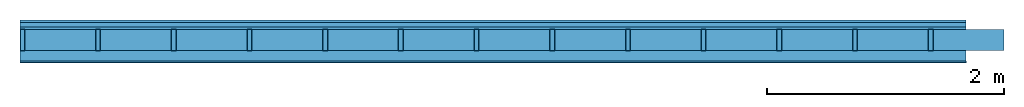
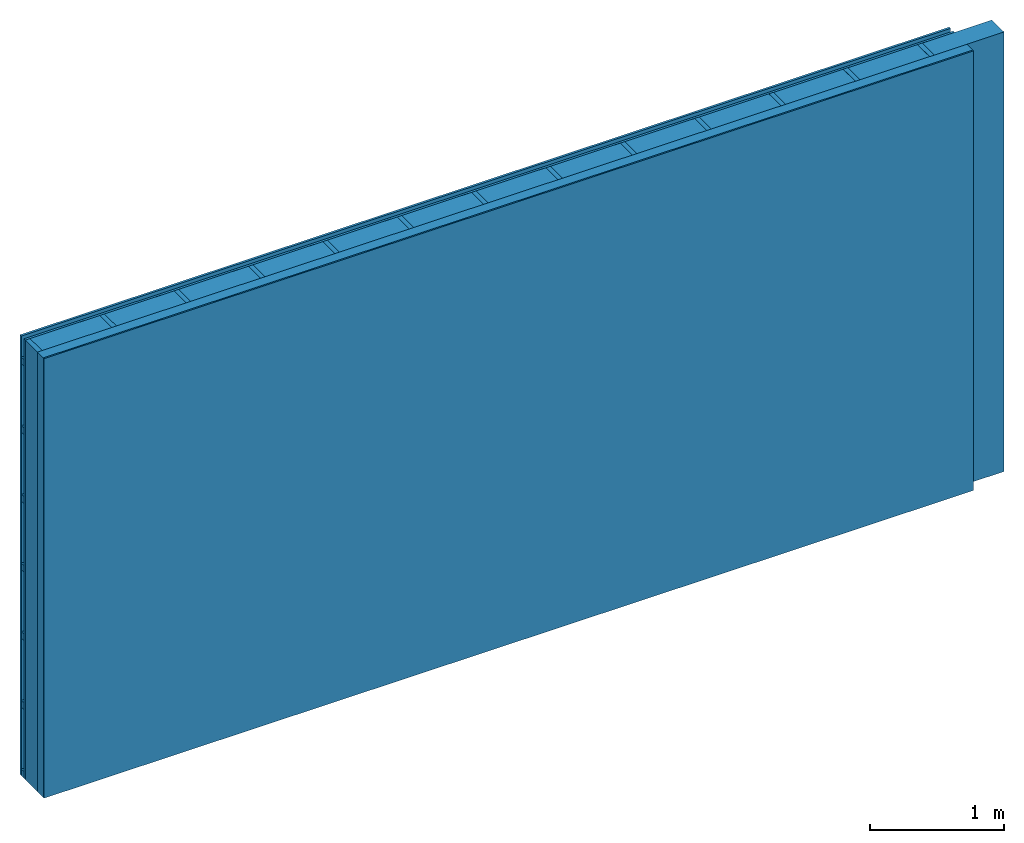
# One storey: 4 plates, 3 members, 1 element without a shape of its own.
"""IFC4 building model written with IfcOpenShell, lengths in metres."""

from ifc_helpers import new_model, si_unit, derived_unit, direction, frame, frame_2d, origin, origin_with_axes, place, context, project, spatial, rectangle, extrude, material, layer, layer_set, type_object, element, aggregate, save


model = new_model("IFC4")

# Units and contexts
plan_context = context("Plan", 3, precision=1e-05, world=origin(), true_north=direction((0.0, 1.0)))
model_context = context("Model", 3, precision=1e-05, world=origin(), true_north=direction((0.0, 1.0)))
ifc_project = project(units=[si_unit("LENGTHUNIT", "METRE"), derived_unit("SOUNDPRESSUREUNIT", [(si_unit("PRESSUREUNIT", "PASCAL", prefix="MICRO"), 0)]), si_unit("ENERGYUNIT", "JOULE", prefix="MEGA"), si_unit("MASSUNIT", "GRAM", prefix="KILO"), derived_unit("THERMALTRANSMITTANCEUNIT", [(si_unit("POWERUNIT", "WATT"), 1), (si_unit("AREAUNIT", "SQUARE_METRE"), -1), (si_unit("THERMODYNAMICTEMPERATUREUNIT", "KELVIN"), -1)]), derived_unit("AREADENSITYUNIT", [(si_unit("MASSUNIT", "GRAM", prefix="KILO"), 1), (si_unit("AREAUNIT", "SQUARE_METRE"), -1)]), derived_unit("USERDEFINED", [(si_unit("ENERGYUNIT", "JOULE", prefix="MEGA"), 1), (si_unit("AREAUNIT", "SQUARE_METRE"), -1)])], contexts=[plan_context, model_context])

# Site, building, storey
site = spatial("IfcSite", under=ifc_project)
building_placement = place(None, origin())
building = spatial("IfcBuilding", under=site, at=building_placement)
storey_placement = place(building_placement, origin())
storey = spatial("IfcBuildingStorey", under=building, at=storey_placement)

# Wall, members, plates
ifc_material_1 = material(Name="Wood cladding horizontal, closed")
ifc_layer_1 = layer(ifc_material_1, 0.02, Name="Cover 1st layer")
ifc_layer_2 = layer(None, 0.04, Name="Battens / profiles (ventilation)")
ifc_material_2 = material(Category="10.009")
ifc_layer_3 = layer(ifc_material_2, 0.02, Name="outside 1st layer")
ifc_material_3 = material(Name="of the art")
ifc_layer_4 = layer(ifc_material_3, 0.0, Name="Bond")
ifc_layer_5 = layer(None, 0.18, Name="Support")
ifc_layer_6 = layer(ifc_material_3, 0.0, Name="Bond")
ifc_material_4 = material(Name="Solid timber panel")
ifc_layer_7 = layer(ifc_material_4, 0.087, Name="1st layer")
ifc_material_5 = material(Name="Plasterboard type A", Category="03.008")
ifc_layer_8 = layer(ifc_material_5, 0.0125, Name="Covering 1st layer")
ifc_material_6 = material(Name="joints", Category="04.017")
ifc_layer_9 = layer(ifc_material_6, 0.0, Name="Surface")
ifc_layer_set = layer_set([ifc_layer_1, ifc_layer_2, ifc_layer_3, ifc_layer_4, ifc_layer_5, ifc_layer_6, ifc_layer_7, ifc_layer_8, ifc_layer_9])
wall_type = type_object("IfcWallType", Name="D1015", PredefinedType="NOTDEFINED", material=ifc_layer_set)
wall_placement = place(None, frame((0.0, 0.0, 0.0), z_axis=(0.0, -1.0, 0.0), x_axis=(1.0, 0.0, 0.0)))
wall = element("IfcWall", 1, at=wall_placement, inside=storey, type_object=wall_type, material=ifc_layer_set, Name="Wall #1")
ifc_material_7 = material()
member_1_placement = place(wall_placement, origin())
member_1 = element("IfcMember", 2, at=member_1_placement, material=ifc_material_7, Name="Battens / profiles (ventilation)", context=plan_context, shape_type="SweptSolid", body=[
    extrude(rectangle(XDim=0.06, YDim=0.04, at=frame_2d((0.03, 0.02), x_axis=(1.0, 0.0))), frame((0.0, 0.0, 0.02), z_axis=(1.0, 0.0, 0.0), x_axis=(0.0, 1.0, 0.0)), (0.0, 0.0, 1.0), 8.0),
    extrude(rectangle(XDim=0.06, YDim=0.04, at=frame_2d((0.03, 0.02), x_axis=(1.0, 0.0))), frame((0.0, 0.625, 0.02), z_axis=(1.0, 0.0, 0.0), x_axis=(0.0, 1.0, 0.0)), (0.0, 0.0, 1.0), 8.0),
    extrude(rectangle(XDim=0.06, YDim=0.04, at=frame_2d((0.03, 0.02), x_axis=(1.0, 0.0))), frame((0.0, 1.25, 0.02), z_axis=(1.0, 0.0, 0.0), x_axis=(0.0, 1.0, 0.0)), (0.0, 0.0, 1.0), 8.0),
    extrude(rectangle(XDim=0.06, YDim=0.04, at=frame_2d((0.03, 0.02), x_axis=(1.0, 0.0))), frame((0.0, 1.875, 0.02), z_axis=(1.0, 0.0, 0.0), x_axis=(0.0, 1.0, 0.0)), (0.0, 0.0, 1.0), 8.0),
    extrude(rectangle(XDim=0.06, YDim=0.04, at=frame_2d((0.03, 0.02), x_axis=(1.0, 0.0))), frame((0.0, 2.5, 0.02), z_axis=(1.0, 0.0, 0.0), x_axis=(0.0, 1.0, 0.0)), (0.0, 0.0, 1.0), 8.0),
    extrude(rectangle(XDim=0.06, YDim=0.04, at=frame_2d((0.03, 0.02), x_axis=(1.0, 0.0))), frame((0.0, 3.125, 0.02), z_axis=(1.0, 0.0, 0.0), x_axis=(0.0, 1.0, 0.0)), (0.0, 0.0, 1.0), 8.0),
    extrude(rectangle(XDim=0.06, YDim=0.04, at=frame_2d((0.03, 0.02), x_axis=(1.0, 0.0))), frame((0.0, 3.75, 0.02), z_axis=(1.0, 0.0, 0.0), x_axis=(0.0, 1.0, 0.0)), (0.0, 0.0, 1.0), 8.0),
])
ifc_material_8 = material()
member_2_placement = place(wall_placement, origin())
member_2 = element("IfcMember", 3, at=member_2_placement, material=ifc_material_8, Name="Support", context=plan_context, shape_type="SweptSolid", body=[
    extrude(rectangle(XDim=0.04, YDim=0.18, at=frame_2d((0.02, 0.09), x_axis=(1.0, 0.0))), frame((0.0, 4.0, 0.08), z_axis=(0.0, -1.0, 0.0), x_axis=(1.0, 0.0, 0.0)), (0.0, 0.0, 1.0), 4.0),
    extrude(rectangle(XDim=0.04, YDim=0.18, at=frame_2d((0.02, 0.09), x_axis=(1.0, 0.0))), frame((0.64, 4.0, 0.08), z_axis=(0.0, -1.0, 0.0), x_axis=(1.0, 0.0, 0.0)), (0.0, 0.0, 1.0), 4.0),
    extrude(rectangle(XDim=0.04, YDim=0.18, at=frame_2d((0.02, 0.09), x_axis=(1.0, 0.0))), frame((1.28, 4.0, 0.08), z_axis=(0.0, -1.0, 0.0), x_axis=(1.0, 0.0, 0.0)), (0.0, 0.0, 1.0), 4.0),
    extrude(rectangle(XDim=0.04, YDim=0.18, at=frame_2d((0.02, 0.09), x_axis=(1.0, 0.0))), frame((1.92, 4.0, 0.08), z_axis=(0.0, -1.0, 0.0), x_axis=(1.0, 0.0, 0.0)), (0.0, 0.0, 1.0), 4.0),
    extrude(rectangle(XDim=0.04, YDim=0.18, at=frame_2d((0.02, 0.09), x_axis=(1.0, 0.0))), frame((2.56, 4.0, 0.08), z_axis=(0.0, -1.0, 0.0), x_axis=(1.0, 0.0, 0.0)), (0.0, 0.0, 1.0), 4.0),
    extrude(rectangle(XDim=0.04, YDim=0.18, at=frame_2d((0.02, 0.09), x_axis=(1.0, 0.0))), frame((3.2, 4.0, 0.08), z_axis=(0.0, -1.0, 0.0), x_axis=(1.0, 0.0, 0.0)), (0.0, 0.0, 1.0), 4.0),
    extrude(rectangle(XDim=0.04, YDim=0.18, at=frame_2d((0.02, 0.09), x_axis=(1.0, 0.0))), frame((3.84, 4.0, 0.08), z_axis=(0.0, -1.0, 0.0), x_axis=(1.0, 0.0, 0.0)), (0.0, 0.0, 1.0), 4.0),
    extrude(rectangle(XDim=0.04, YDim=0.18, at=frame_2d((0.02, 0.09), x_axis=(1.0, 0.0))), frame((4.48, 4.0, 0.08), z_axis=(0.0, -1.0, 0.0), x_axis=(1.0, 0.0, 0.0)), (0.0, 0.0, 1.0), 4.0),
    extrude(rectangle(XDim=0.04, YDim=0.18, at=frame_2d((0.02, 0.09), x_axis=(1.0, 0.0))), frame((5.12, 4.0, 0.08), z_axis=(0.0, -1.0, 0.0), x_axis=(1.0, 0.0, 0.0)), (0.0, 0.0, 1.0), 4.0),
    extrude(rectangle(XDim=0.04, YDim=0.18, at=frame_2d((0.02, 0.09), x_axis=(1.0, 0.0))), frame((5.76, 4.0, 0.08), z_axis=(0.0, -1.0, 0.0), x_axis=(1.0, 0.0, 0.0)), (0.0, 0.0, 1.0), 4.0),
    extrude(rectangle(XDim=0.04, YDim=0.18, at=frame_2d((0.02, 0.09), x_axis=(1.0, 0.0))), frame((6.4, 4.0, 0.08), z_axis=(0.0, -1.0, 0.0), x_axis=(1.0, 0.0, 0.0)), (0.0, 0.0, 1.0), 4.0),
    extrude(rectangle(XDim=0.04, YDim=0.18, at=frame_2d((0.02, 0.09), x_axis=(1.0, 0.0))), frame((7.04, 4.0, 0.08), z_axis=(0.0, -1.0, 0.0), x_axis=(1.0, 0.0, 0.0)), (0.0, 0.0, 1.0), 4.0),
    extrude(rectangle(XDim=0.04, YDim=0.18, at=frame_2d((0.02, 0.09), x_axis=(1.0, 0.0))), frame((7.68, 4.0, 0.08), z_axis=(0.0, -1.0, 0.0), x_axis=(1.0, 0.0, 0.0)), (0.0, 0.0, 1.0), 4.0),
])
ifc_material_9 = material(Name="wool")
member_3_placement = place(wall_placement, origin())
member_3 = element("IfcMember", 4, at=member_3_placement, material=ifc_material_9, Name="Cavity", context=plan_context, shape_type="SweptSolid", body=[
    extrude(rectangle(XDim=0.6, YDim=0.18, at=frame_2d((0.3, 0.09), x_axis=(1.0, 0.0))), frame((0.04, 4.0, 0.08), z_axis=(0.0, -1.0, 0.0), x_axis=(1.0, 0.0, 0.0)), (0.0, 0.0, 1.0), 4.0),
    extrude(rectangle(XDim=0.6, YDim=0.18, at=frame_2d((0.3, 0.09), x_axis=(1.0, 0.0))), frame((0.68, 4.0, 0.08), z_axis=(0.0, -1.0, 0.0), x_axis=(1.0, 0.0, 0.0)), (0.0, 0.0, 1.0), 4.0),
    extrude(rectangle(XDim=0.6, YDim=0.18, at=frame_2d((0.3, 0.09), x_axis=(1.0, 0.0))), frame((1.32, 4.0, 0.08), z_axis=(0.0, -1.0, 0.0), x_axis=(1.0, 0.0, 0.0)), (0.0, 0.0, 1.0), 4.0),
    extrude(rectangle(XDim=0.6, YDim=0.18, at=frame_2d((0.3, 0.09), x_axis=(1.0, 0.0))), frame((1.96, 4.0, 0.08), z_axis=(0.0, -1.0, 0.0), x_axis=(1.0, 0.0, 0.0)), (0.0, 0.0, 1.0), 4.0),
    extrude(rectangle(XDim=0.6, YDim=0.18, at=frame_2d((0.3, 0.09), x_axis=(1.0, 0.0))), frame((2.6, 4.0, 0.08), z_axis=(0.0, -1.0, 0.0), x_axis=(1.0, 0.0, 0.0)), (0.0, 0.0, 1.0), 4.0),
    extrude(rectangle(XDim=0.6, YDim=0.18, at=frame_2d((0.3, 0.09), x_axis=(1.0, 0.0))), frame((3.24, 4.0, 0.08), z_axis=(0.0, -1.0, 0.0), x_axis=(1.0, 0.0, 0.0)), (0.0, 0.0, 1.0), 4.0),
    extrude(rectangle(XDim=0.6, YDim=0.18, at=frame_2d((0.3, 0.09), x_axis=(1.0, 0.0))), frame((3.88, 4.0, 0.08), z_axis=(0.0, -1.0, 0.0), x_axis=(1.0, 0.0, 0.0)), (0.0, 0.0, 1.0), 4.0),
    extrude(rectangle(XDim=0.6, YDim=0.18, at=frame_2d((0.3, 0.09), x_axis=(1.0, 0.0))), frame((4.52, 4.0, 0.08), z_axis=(0.0, -1.0, 0.0), x_axis=(1.0, 0.0, 0.0)), (0.0, 0.0, 1.0), 4.0),
    extrude(rectangle(XDim=0.6, YDim=0.18, at=frame_2d((0.3, 0.09), x_axis=(1.0, 0.0))), frame((5.16, 4.0, 0.08), z_axis=(0.0, -1.0, 0.0), x_axis=(1.0, 0.0, 0.0)), (0.0, 0.0, 1.0), 4.0),
    extrude(rectangle(XDim=0.6, YDim=0.18, at=frame_2d((0.3, 0.09), x_axis=(1.0, 0.0))), frame((5.8, 4.0, 0.08), z_axis=(0.0, -1.0, 0.0), x_axis=(1.0, 0.0, 0.0)), (0.0, 0.0, 1.0), 4.0),
    extrude(rectangle(XDim=0.6, YDim=0.18, at=frame_2d((0.3, 0.09), x_axis=(1.0, 0.0))), frame((6.44, 4.0, 0.08), z_axis=(0.0, -1.0, 0.0), x_axis=(1.0, 0.0, 0.0)), (0.0, 0.0, 1.0), 4.0),
    extrude(rectangle(XDim=0.6, YDim=0.18, at=frame_2d((0.3, 0.09), x_axis=(1.0, 0.0))), frame((7.08, 4.0, 0.08), z_axis=(0.0, -1.0, 0.0), x_axis=(1.0, 0.0, 0.0)), (0.0, 0.0, 1.0), 4.0),
    extrude(rectangle(XDim=0.6, YDim=0.18, at=frame_2d((0.3, 0.09), x_axis=(1.0, 0.0))), frame((7.72, 4.0, 0.08), z_axis=(0.0, -1.0, 0.0), x_axis=(1.0, 0.0, 0.0)), (0.0, 0.0, 1.0), 4.0),
])
plate_1_placement = place(wall_placement, origin())
plate_1 = element("IfcPlate", 5, at=plate_1_placement, material=ifc_material_1, Name="Cover 1st layer", context=plan_context, shape_type="SweptSolid", body=[
    extrude(rectangle(XDim=8.0, YDim=4.0, at=frame_2d((4.0, 2.0), x_axis=(1.0, 0.0))), origin_with_axes(), (0.0, 0.0, 1.0), 0.02),
])
plate_2_placement = place(wall_placement, origin())
plate_2 = element("IfcPlate", 6, at=plate_2_placement, material=ifc_material_2, Name="outside 1st layer", context=plan_context, shape_type="SweptSolid", body=[
    extrude(rectangle(XDim=8.0, YDim=4.0, at=frame_2d((4.0, 2.0), x_axis=(1.0, 0.0))), frame((0.0, 0.0, 0.06), z_axis=(0.0, 0.0, 1.0), x_axis=(1.0, 0.0, 0.0)), (0.0, 0.0, 1.0), 0.02),
])
plate_3_placement = place(wall_placement, origin())
plate_3 = element("IfcPlate", 7, at=plate_3_placement, material=ifc_material_4, Name="1st layer", context=plan_context, shape_type="SweptSolid", body=[
    extrude(rectangle(XDim=8.0, YDim=4.0, at=frame_2d((4.0, 2.0), x_axis=(1.0, 0.0))), frame((0.0, 0.0, 0.26), z_axis=(0.0, 0.0, 1.0), x_axis=(1.0, 0.0, 0.0)), (0.0, 0.0, 1.0), 0.087),
])
plate_4_placement = place(wall_placement, origin())
plate_4 = element("IfcPlate", 8, at=plate_4_placement, material=ifc_material_5, Name="Covering 1st layer", context=plan_context, shape_type="SweptSolid", body=[
    extrude(rectangle(XDim=8.0, YDim=4.0, at=frame_2d((4.0, 2.0), x_axis=(1.0, 0.0))), frame((0.0, 0.0, 0.347), z_axis=(0.0, 0.0, 1.0), x_axis=(1.0, 0.0, 0.0)), (0.0, 0.0, 1.0), 0.0125),
])
aggregate(wall, [plate_1, member_1, plate_2, member_2, member_3, plate_3, plate_4])

save(model, "model.ifc")
